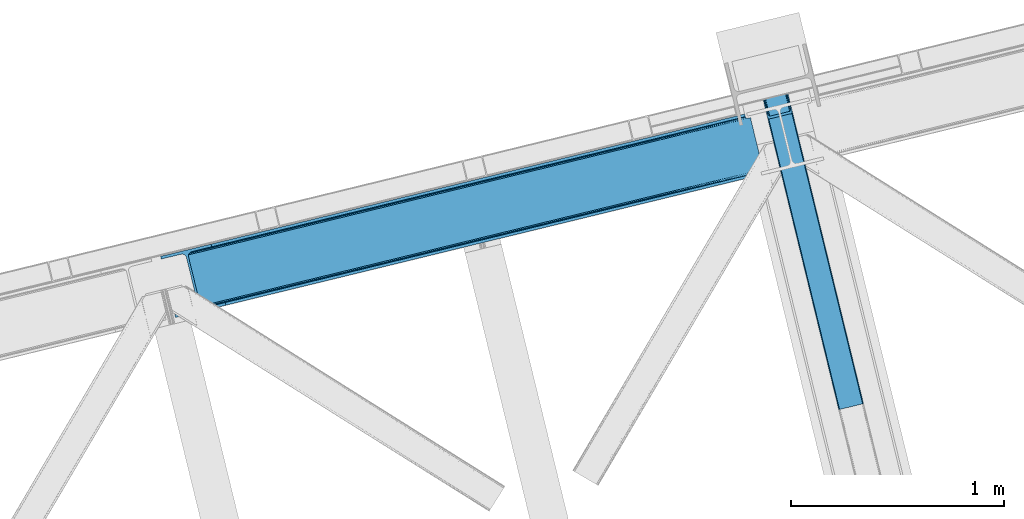
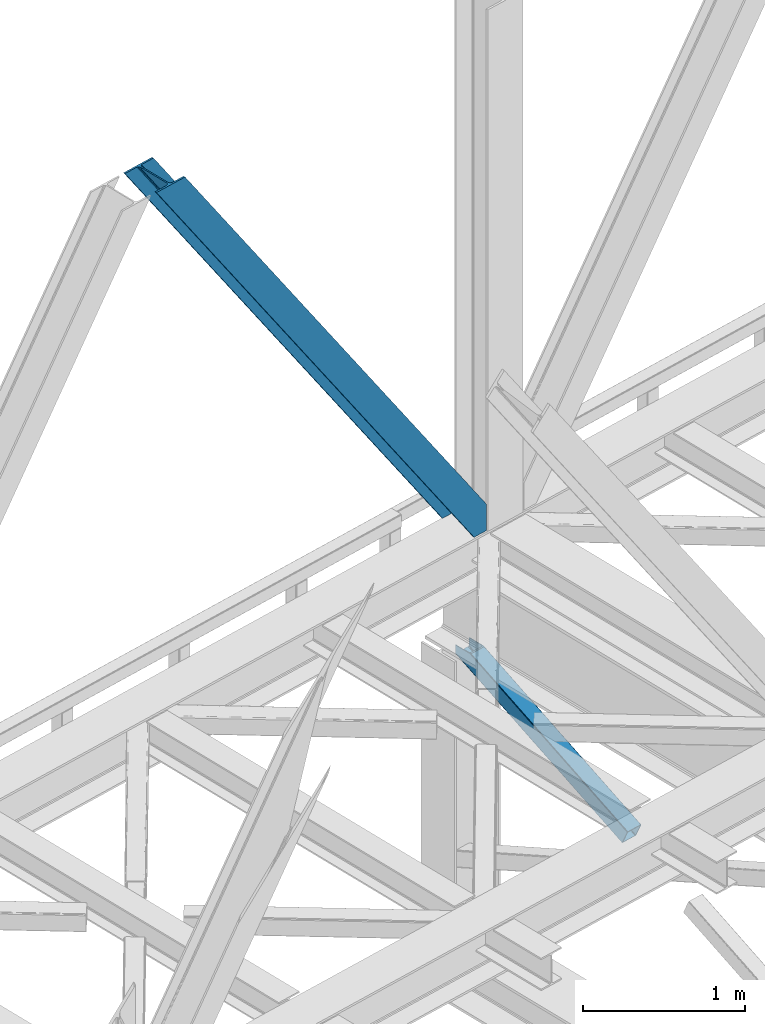
# One storey, part 30 of 93: 2 members.
"""IFC4 building model written with IfcOpenShell, lengths in millimetres."""

from ifc_helpers import new_model, entity, si_unit, converted_unit, derived_unit, direction, frame, origin, place, context, subcontext, project, spatial, triangles, type_object, element, save


model = new_model("IFC4")

# Units and contexts
model_context = context("Model", 3, precision=0.01, world=origin(), true_north=direction((6.12303176911189e-17, 1.0)))
plan_context = context("Plan", 3, precision=0.01, world=origin(), true_north=direction((6.12303176911189e-17, 1.0)))
body_context = subcontext(model_context, "Body", "Model", "MODEL_VIEW")
ifc_project = project(units=[si_unit("LENGTHUNIT", "METRE", prefix="MILLI"), si_unit("AREAUNIT", "SQUARE_METRE"), si_unit("VOLUMEUNIT", "CUBIC_METRE"), converted_unit("PLANEANGLEUNIT", "DEGREE", entity("IfcRatioMeasure", 0.0174532925199433), si_unit("PLANEANGLEUNIT", "RADIAN"), dimensions=[0, 0, 0, 0, 0, 0, 0]), si_unit("MASSUNIT", "GRAM", prefix="KILO"), derived_unit("MASSDENSITYUNIT", [(si_unit("MASSUNIT", "GRAM", prefix="KILO"), 1), (si_unit("LENGTHUNIT", "METRE"), -3)]), derived_unit("MOMENTOFINERTIAUNIT", [(si_unit("LENGTHUNIT", "METRE"), 4)]), si_unit("TIMEUNIT", "SECOND"), si_unit("FREQUENCYUNIT", "HERTZ"), si_unit("THERMODYNAMICTEMPERATUREUNIT", "DEGREE_CELSIUS"), derived_unit("THERMALTRANSMITTANCEUNIT", [(si_unit("MASSUNIT", "GRAM", prefix="KILO"), 1), (si_unit("THERMODYNAMICTEMPERATUREUNIT", "KELVIN"), -1), (si_unit("TIMEUNIT", "SECOND"), -3)]), derived_unit("VOLUMETRICFLOWRATEUNIT", [(si_unit("LENGTHUNIT", "METRE"), 3), (si_unit("TIMEUNIT", "SECOND"), -1)]), derived_unit("MASSFLOWRATEUNIT", [(si_unit("MASSUNIT", "GRAM", prefix="KILO"), 1), (si_unit("TIMEUNIT", "SECOND"), -1)]), derived_unit("ROTATIONALFREQUENCYUNIT", [(si_unit("TIMEUNIT", "SECOND"), -1)]), si_unit("ELECTRICCURRENTUNIT", "AMPERE"), si_unit("ELECTRICVOLTAGEUNIT", "VOLT"), si_unit("POWERUNIT", "WATT"), si_unit("FORCEUNIT", "NEWTON", prefix="KILO"), si_unit("ILLUMINANCEUNIT", "LUX"), si_unit("LUMINOUSFLUXUNIT", "LUMEN"), si_unit("LUMINOUSINTENSITYUNIT", "CANDELA"), derived_unit("USERDEFINED", [(si_unit("MASSUNIT", "GRAM", prefix="KILO"), -1), (si_unit("LENGTHUNIT", "METRE"), -2), (si_unit("TIMEUNIT", "SECOND"), 3), (si_unit("LUMINOUSFLUXUNIT", "LUMEN"), 1)]), derived_unit("LINEARVELOCITYUNIT", [(si_unit("LENGTHUNIT", "METRE"), 1), (si_unit("TIMEUNIT", "SECOND"), -1)]), si_unit("PRESSUREUNIT", "PASCAL"), derived_unit("USERDEFINED", [(si_unit("LENGTHUNIT", "METRE"), -2), (si_unit("MASSUNIT", "GRAM", prefix="KILO"), 1), (si_unit("TIMEUNIT", "SECOND"), -2)]), derived_unit("LINEARFORCEUNIT", [(si_unit("MASSUNIT", "GRAM", prefix="KILO"), 1), (si_unit("LENGTHUNIT", "METRE"), 1), (si_unit("TIMEUNIT", "SECOND"), -2), (si_unit("LENGTHUNIT", "METRE"), -1)]), derived_unit("PLANARFORCEUNIT", [(si_unit("MASSUNIT", "GRAM", prefix="KILO"), 1), (si_unit("LENGTHUNIT", "METRE"), 1), (si_unit("TIMEUNIT", "SECOND"), -2), (si_unit("LENGTHUNIT", "METRE"), -2)])], contexts=[model_context, plan_context])

# Site, building, storey
site_placement = place(None, origin())
site = spatial("IfcSite", under=ifc_project, at=site_placement, CompositionType="ELEMENT")
building_placement = place(site_placement, origin())
building = spatial("IfcBuilding", under=site, at=building_placement, CompositionType="ELEMENT")
storey_placement = place(building_placement, frame((0.0, 0.0, 15900.0)))
storey = spatial("IfcBuildingStorey", under=building, at=storey_placement, CompositionType="ELEMENT", Elevation=15900.0)

# Members
member_type_1 = type_object("IfcMemberType", PredefinedType="BRACE")
member_1_placement = place(storey_placement, frame((-58108.1461669922, 6493.08332061768, 3694.99929199219)))
element("IfcMember", 1, at=member_1_placement, inside=storey, type_object=member_type_1, ObjectType="Steel Vertical Brace", PredefinedType="BRACE", context=body_context, shape_type="Tessellation", body=[
    triangles([(2824.16715087891, 696.208666992187, 0.781347656247817), (2824.83687744141, 695.227331542969, 1.0697021484375), (2823.33929443359, 694.862237548828, 0.0), (2821.44638671875, 702.634437561035, 0.0), (2812.37717285156, 692.190307617188, 19.5569458007813), (2812.37717285156, 692.190307617188, 0.0), (2386.756640625, 583.574263000489, 658.75048828125), (2392.34234619141, 580.919192504883, 662.07819213867), (2803.98698730469, 681.261904907226, 51.2480346679658), (2804.11256103516, 683.186206054687, 44.4996093749978), (2382.25924072266, 588.488497924805, 656.525042724606), (2808.48438720703, 690.37995300293, 26.4030395507798), (2805.01483154297, 685.664543151855, 38.2720825195283), (2805.58223876954, 687.217936706543, 34.3676696777329), (630.515002441411, 150.046073913574, 3288.98063964843), (624.692102050787, 150.036772155762, 3285.05529785156), (211.331286621098, 47.865682983399, 3911.00081176758), (202.862036132814, 47.2110717773439, 3911.00081176758), (619.106396484378, 152.691261291504, 3281.72759399414), (195.034606933594, 49.3190826416021, 3911.00081176758), (614.608996582036, 157.60549621582, 3279.50447387695), (189.03962402344, 53.8676422119142, 3911.00081176758), (611.88358154297, 164.031266784668, 3278.7231262207), (185.784008789065, 60.1649322509766, 3911.00081176758), (2804.10325927735, 679.880593872071, 63.6403015136711), (2398.16524658204, 580.929075622559, 666.003533935545), (1950.42978515625, 473.1990234375, 1317.82188720703), (1956.25268554688, 473.208325195313, 1321.74955444336), (1508.5172241211, 365.478273010254, 1973.56790771484), (1514.34012451172, 365.487574768066, 1977.49324951172), (1072.42756347657, 257.766824340821, 2633.23694458008), (1066.60466308594, 257.757522583008, 2629.3116027832), (1944.84407958985, 475.853512573242, 1314.49418334961), (1502.93151855469, 368.132762145996, 1970.23787841797), (1061.01895751953, 260.41201171875, 2625.98389892578), (1940.3466796875, 480.767747497559, 1312.27106323242), (1498.43411865235, 373.046997070313, 1968.01475830078), (1056.52155761719, 265.326246643067, 2623.75845336914), (2379.5338256836, 594.91368713379, 655.74602050781), (1937.62126464844, 487.192936706543, 1311.48971557617), (1495.70870361329, 379.47276763916, 1967.23341064453), (1053.79614257813, 271.752017211914, 2622.97710571289), (2766.2637084961, 929.006085205078, 0.0), (2324.35114746094, 821.285334777832, 655.74602050781), (1882.43858642579, 713.564584350586, 1311.48971557617), (1440.52602539063, 605.844415283203, 1967.23341064453), (998.613464355469, 498.123664855957, 2622.97710571289), (556.705554199223, 390.402914428711, 3278.7231262207), (130.605981445318, 286.53657989502, 3911.00081176758), (303.26520996094, 70.2747802734375, 3911.00081176758), (2804.10325927735, 679.880593872071, 200.055230712889), (2807.13563232422, 667.239505004883, 200.120343017577), (2804.2939453125, 678.898095703125, 200.120343017577), (306.344091796876, 57.6441558837896, 3911.00081176758), (2807.13563232422, 667.239505004883, 0.0), (2804.2939453125, 678.898095703125, 0.0), (2803.9962890625, 682.092668151856, 0.0), (2804.11256103516, 683.186206054687, 2.42078247070094), (2804.71717529297, 685.456997680664, 5.12991943359157), (2805.58223876954, 687.217936706543, 5.67639770507594), (2807.01470947266, 689.087008666992, 4.89505004882813), (2808.48438720703, 690.37995300293, 3.35328369140552), (2811.03771972656, 691.772309875489, 0.0), (2705.51857910157, 642.469505310059, 0.0), (69.8608520507842, 0.0, 3911.00081176758), (2794.37362060547, 677.509226989746, 0.0), (2801.99641113282, 681.140400695801, 0.0), (2702.44434814453, 655.099548339844, 0.0), (66.7819702148481, 12.6300430297852, 3911.00081176758), (1480.00268554688, 357.117155456544, 1950.37164916992), (1034.28570556641, 248.469717407227, 2611.75686035156), (588.573376464847, 139.822279357911, 3273.1420715332), (158.71589355469, 35.0397216796873, 3911.00081176758), (1925.71501464844, 465.76459350586, 1288.98643798828), (2371.42734375, 574.412031555176, 627.598901367186), (2376.60377197266, 577.083380126954, 631.526568603513), (2380.34307861328, 582.010986328125, 634.854272460936), (2381.53370361328, 595.402029418946, 637.858740234373), (2811.39583740235, 700.184587097168, 0.0), (2811.09353027344, 693.083276367188, 0.0), (2382.07320556641, 588.443151855469, 637.077392578125), (598.679736328129, 160.81227722168, 3283.40191040039), (599.21923828125, 153.853399658204, 3282.62056274414), (175.738110351565, 57.7150817871097, 3911.00081176758), (175.747412109376, 50.6283050537113, 3911.00081176758), (597.484460449225, 147.420652770997, 3280.39744262695), (172.515051269533, 43.8298828124998, 3911.00081176758), (593.749804687504, 142.493627929688, 3277.06973876953), (166.5340209961, 38.3557983398441, 3911.00081176758), (1936.36087646485, 479.795713806153, 1298.46260375976), (1935.82137451172, 486.754591369629, 1299.24395141601), (1490.10904541016, 378.107153320313, 1960.63148803711), (1490.64389648438, 371.148275756836, 1959.85014038086), (1044.93156738282, 262.50083770752, 2621.2353515625), (1044.39206542969, 269.459715270997, 2622.01669921875), (1934.62609863281, 473.362966918946, 1296.23948364258), (1488.91376953125, 364.715528869629, 1957.62469482422), (1043.20144042969, 256.068090820313, 2619.01223144531), (1930.8914428711, 468.435942077637, 1292.91177978515), (1485.17446289063, 359.788504028321, 1954.2969909668), (1039.46213378906, 251.141065979004, 2615.68220214844), (2756.21315917969, 926.556234741211, 0.0), (2326.35567626954, 821.773677062988, 637.858740234373), (1434.9263671875, 604.478800964355, 1960.63148803711), (1880.64334716797, 713.126239013672, 1299.24395141601), (989.214038085942, 495.831362915039, 2622.01669921875), (543.501708984375, 387.183924865722, 3283.40191040039), (120.555432128909, 284.086729431153, 3911.00081176758), (2752.67849121094, 932.723881530762, 0.0), (2753.40867919922, 934.106936645509, 0.0), (2752.02736816407, 933.862184143067, 0.0), (2764.37080078125, 936.778866577149, 0.0), (2753.40867919922, 934.106936645509, 19.5569458007813), (2765.86838378906, 937.143960571289, 1.0697021484375), (2765.72420654297, 935.965544128419, 0.781347656247817), (2325.54642333985, 834.677540588379, 658.75048828125), (2749.12056884766, 933.923226928711, 26.4030395507798), (2745.08825683594, 935.395230102539, 34.3676696777329), (2323.81629638672, 828.244793701172, 656.525042724606), (2743.50695800781, 936.560275268555, 38.5441589355469), (556.166052246095, 397.361791992188, 3279.50447387695), (130.592028808598, 293.624519348145, 3911.00081176758), (557.896179199219, 403.794538879395, 3281.72759399414), (133.824389648442, 300.422360229492, 3911.00081176758), (561.635485839848, 408.721563720704, 3285.05529785156), (139.805419921875, 305.895863342285, 3911.00081176758), (566.811914062506, 411.393493652344, 3288.98063964843), (147.628198242193, 309.212521362305, 3911.00081176758), (2740.93037109375, 939.947277832031, 51.2480346679658), (2740.39552001953, 941.22801361084, 63.6403015136711), (2329.28572998047, 839.604565429688, 662.07819213867), (2334.45750732422, 842.276495361329, 666.003533935545), (2742.08843994141, 938.421208190918, 45.5251281738274), (1881.90373535157, 720.524043273926, 1312.27106323242), (1439.99117431641, 612.80329284668, 1968.01475830078), (998.07861328125, 505.082542419434, 2623.75845336914), (1883.63386230469, 726.956790161133, 1314.49418334961), (1441.72130126954, 619.236039733887, 1970.23787841797), (999.808740234381, 511.515289306641, 2625.98389892578), (1887.37316894531, 731.883815002441, 1317.82188720703), (1445.46060791016, 624.163064575196, 1973.56790771484), (1003.548046875, 516.442314147949, 2629.3116027832), (1892.54494628907, 734.555744934082, 1321.74955444336), (1450.63238525391, 626.834994506836, 1977.49324951172), (1008.72447509766, 519.11424407959, 2633.23694458008), (2740.39552001953, 941.22801361084, 200.055230712889), (239.557470703126, 331.622200012207, 3911.00081176758), (2749.12056884766, 933.923226928711, 3.35328369140552), (2745.08825683594, 935.395230102539, 5.67639770507594), (2747.22301025391, 934.392384338379, 4.89272460937354), (2743.50695800781, 936.560275268555, 5.12991943359157), (2740.11646728516, 942.189001464844, 0.0), (2741.92565917969, 938.297378540039, 2.42078247070094), (2740.11646728516, 942.189001464844, 200.120343017577), (2741.32104492188, 939.215927124023, 0.0), (2323.63026123047, 828.2000289917, 637.077392578125), (2319.13286132813, 833.113682556153, 634.854272460936), (2313.54715576172, 835.768171691895, 631.526568603513), (2307.7242553711, 835.758869934082, 627.598901367186), (2730.66588134766, 938.856646728516, 0.0), (2739.1072265625, 939.140931701661, 0.0), (524.865637207033, 401.16969909668, 3273.1420715332), (530.693188476565, 401.178419494629, 3277.06973876953), (103.477404785161, 297.041171264648, 3911.00081176758), (95.0081542968765, 296.387141418457, 3911.00081176758), (536.278894042975, 398.523930358887, 3280.39744262695), (111.309484863283, 294.933160400391, 3911.00081176758), (540.776293945317, 393.610276794434, 3282.62056274414), (117.304467773443, 290.384600830078, 3911.00081176758), (1867.83017578125, 727.120733642579, 1292.91177978515), (1862.00727539063, 727.112013244629, 1288.98643798828), (1416.29494628907, 618.463993835449, 1950.37164916992), (1422.11784667969, 618.473295593262, 1954.2969909668), (976.405517578125, 509.825857543946, 2615.68220214844), (970.582617187501, 509.817137145997, 2611.75686035156), (1873.41588134766, 724.466244506836, 1296.23948364258), (1427.70355224609, 615.81880645752, 1957.62469482422), (981.991223144534, 507.171368408203, 2619.01223144531), (1877.91793212891, 719.552590942383, 1298.46260375976), (1432.20095214844, 610.905152893067, 1959.85014038086), (986.488623046876, 502.25771484375, 2621.2353515625), (2737.27478027344, 953.847592163086, 200.120343017577), (236.47858886719, 344.252243041992, 3911.00081176758), (2737.27478027344, 953.847592163086, 0.0), (0.0, 286.608087158203, 3911.00081176758), (3.07888183594332, 273.977462768555, 3911.00081176758), (2635.65772705078, 929.077592468262, 0.0), (2638.73660888672, 916.446968078613, 0.0)], [[1, 2, 3], [3, 4, 1], [2, 5, 6], [6, 3, 2], [7, 8, 9], [9, 10, 7], [11, 12, 5], [5, 1, 11], [5, 2, 1], [11, 7, 13], [13, 14, 11], [14, 12, 11], [15, 16, 17], [18, 17, 16], [16, 19, 18], [20, 18, 19], [19, 21, 20], [22, 20, 21], [21, 23, 22], [24, 22, 23], [10, 13, 7], [25, 9, 8], [8, 26, 25], [26, 8, 27], [27, 28, 26], [28, 27, 29], [29, 30, 28], [30, 29, 31], [32, 31, 29], [31, 32, 16], [16, 15, 31], [8, 7, 27], [33, 27, 7], [27, 33, 34], [34, 29, 27], [29, 34, 35], [35, 32, 29], [32, 35, 16], [19, 16, 35], [7, 11, 36], [36, 33, 7], [33, 36, 34], [37, 34, 36], [34, 37, 35], [38, 35, 37], [35, 38, 21], [21, 19, 35], [1, 4, 11], [39, 11, 4], [11, 39, 40], [40, 36, 11], [36, 40, 41], [41, 37, 36], [37, 41, 42], [42, 38, 37], [38, 42, 21], [23, 21, 42], [4, 43, 44], [45, 39, 44], [41, 40, 45], [41, 45, 46], [44, 39, 4], [45, 40, 39], [42, 41, 46], [46, 47, 42], [47, 48, 23], [49, 24, 48], [47, 23, 42], [48, 24, 23], [50, 51, 30], [30, 31, 50], [31, 15, 50], [17, 50, 15], [28, 30, 51], [51, 25, 26], [26, 28, 51], [52, 53, 54], [53, 51, 50], [50, 54, 53], [52, 55, 53], [56, 53, 55], [56, 9, 25], [56, 57, 58], [58, 10, 56], [10, 9, 56], [59, 60, 14], [14, 13, 59], [10, 58, 59], [60, 61, 12], [12, 14, 60], [5, 62, 63], [63, 6, 5], [5, 12, 62], [61, 62, 12], [13, 10, 59], [25, 51, 53], [53, 56, 25], [54, 64, 52], [54, 65, 64], [64, 55, 52], [56, 66, 67], [55, 66, 56], [67, 57, 56], [64, 66, 55], [64, 68, 66], [68, 64, 69], [65, 69, 64], [69, 70, 68], [71, 69, 72], [69, 71, 70], [69, 73, 72], [74, 68, 70], [66, 68, 75], [74, 75, 68], [67, 76, 58], [76, 77, 59], [59, 58, 76], [76, 67, 66], [78, 79, 80], [81, 60, 59], [81, 80, 62], [62, 61, 81], [61, 60, 81], [80, 63, 62], [59, 77, 81], [80, 81, 78], [82, 83, 84], [85, 84, 83], [83, 86, 85], [87, 85, 86], [86, 88, 87], [89, 87, 88], [88, 72, 89], [73, 89, 72], [66, 75, 76], [58, 57, 67], [78, 81, 90], [90, 91, 78], [91, 90, 92], [93, 92, 90], [92, 93, 94], [94, 95, 92], [95, 94, 83], [83, 82, 95], [81, 77, 90], [96, 90, 77], [90, 96, 93], [97, 93, 96], [93, 97, 94], [98, 94, 97], [94, 98, 83], [86, 83, 98], [77, 76, 99], [99, 96, 77], [96, 99, 100], [100, 97, 96], [97, 100, 101], [101, 98, 97], [98, 101, 88], [88, 86, 98], [76, 75, 99], [74, 99, 75], [99, 74, 70], [70, 100, 99], [100, 70, 101], [71, 101, 70], [101, 71, 72], [72, 88, 101], [102, 79, 78], [91, 103, 78], [104, 105, 91], [104, 91, 92], [78, 103, 102], [91, 105, 103], [106, 104, 92], [92, 95, 106], [95, 82, 107], [84, 108, 82], [95, 107, 106], [82, 108, 107], [109, 102, 110], [6, 79, 80], [6, 80, 63], [110, 111, 109], [3, 79, 6], [79, 4, 102], [3, 4, 79], [43, 102, 4], [102, 112, 110], [112, 102, 43], [113, 114, 110], [112, 110, 114], [114, 115, 112], [43, 112, 115], [116, 117, 118], [119, 115, 113], [113, 116, 119], [113, 117, 116], [115, 114, 113], [118, 120, 116], [48, 121, 122], [122, 49, 48], [121, 123, 124], [124, 122, 121], [123, 125, 126], [126, 124, 123], [125, 127, 128], [128, 126, 125], [129, 130, 131], [132, 131, 130], [133, 116, 120], [116, 133, 129], [131, 116, 129], [43, 115, 119], [119, 44, 43], [44, 119, 45], [134, 45, 119], [45, 134, 46], [135, 46, 134], [46, 135, 136], [136, 47, 46], [47, 136, 121], [121, 48, 47], [119, 116, 134], [137, 134, 116], [134, 137, 138], [138, 135, 134], [135, 138, 139], [139, 136, 135], [136, 139, 121], [123, 121, 139], [116, 131, 140], [140, 137, 116], [137, 140, 138], [141, 138, 140], [138, 141, 139], [142, 139, 141], [139, 142, 125], [125, 123, 139], [131, 132, 140], [143, 140, 132], [140, 143, 141], [144, 141, 143], [141, 144, 145], [145, 142, 141], [142, 145, 127], [127, 125, 142], [144, 146, 147], [147, 127, 145], [127, 147, 128], [145, 144, 147], [146, 144, 143], [143, 132, 146], [130, 146, 132], [113, 110, 111], [148, 117, 113], [149, 118, 117], [117, 148, 150], [151, 133, 120], [118, 149, 151], [151, 120, 118], [152, 133, 153], [152, 129, 133], [146, 130, 154], [152, 154, 130], [130, 129, 152], [153, 155, 152], [151, 153, 133], [117, 150, 149], [111, 148, 113], [156, 150, 148], [156, 149, 150], [148, 109, 156], [148, 111, 109], [156, 157, 151], [151, 149, 156], [103, 156, 109], [158, 159, 160], [158, 153, 151], [158, 161, 153], [161, 155, 153], [151, 157, 158], [160, 161, 158], [162, 163, 164], [164, 165, 162], [163, 166, 167], [167, 164, 163], [166, 168, 169], [169, 167, 166], [168, 107, 108], [108, 169, 168], [109, 102, 103], [159, 158, 170], [170, 171, 159], [171, 170, 172], [173, 172, 170], [172, 173, 174], [174, 175, 172], [175, 174, 163], [163, 162, 175], [158, 157, 176], [176, 170, 158], [170, 176, 173], [177, 173, 176], [173, 177, 174], [178, 174, 177], [174, 178, 163], [166, 163, 178], [157, 156, 176], [179, 176, 156], [176, 179, 180], [180, 177, 176], [177, 180, 181], [181, 178, 177], [178, 181, 168], [168, 166, 178], [156, 103, 105], [105, 179, 156], [179, 105, 104], [104, 180, 179], [180, 104, 181], [106, 181, 104], [181, 106, 168], [107, 168, 106], [146, 154, 147], [154, 182, 183], [183, 147, 154], [154, 152, 184], [184, 182, 154], [108, 84, 49], [87, 89, 18], [73, 65, 54], [69, 65, 73], [89, 73, 17], [84, 85, 22], [85, 87, 20], [167, 126, 164], [185, 165, 183], [165, 164, 128], [185, 186, 165], [167, 169, 124], [169, 108, 122], [49, 84, 24], [17, 18, 89], [22, 85, 20], [18, 20, 87], [22, 24, 84], [54, 17, 73], [54, 50, 17], [128, 164, 126], [124, 169, 122], [49, 122, 108], [124, 126, 167], [128, 183, 165], [183, 128, 147], [152, 160, 184], [155, 161, 152], [152, 161, 160], [160, 187, 184], [187, 160, 188], [183, 187, 185], [187, 183, 182], [184, 187, 182], [172, 186, 188], [162, 186, 175], [162, 165, 186], [172, 175, 186], [188, 171, 172], [159, 171, 188], [188, 160, 159], [187, 188, 185], [186, 185, 188]]),
])
member_type_2 = type_object("IfcMemberType", PredefinedType="BRACE")
member_2_placement = place(storey_placement, frame((-55294.262109375, 6062.41018981934, 1850.35374755859)))
element("IfcMember", 2, at=member_2_placement, inside=storey, type_object=member_type_2, ObjectType="Steel Vertical Brace", PredefinedType="BRACE", context=body_context, shape_type="Tessellation", body=[
    triangles([(109.783996582031, 1519.24680175781, 671.707836914062), (462.204345703125, 73.4902816772465, 0.0), (359.21993408203, 48.3865814208984, 0.0), (6.79958496093604, 1494.14310150147, 671.707836914062), (464.859997558589, 73.9117675781254, 0.48601684570167), (467.213342285155, 73.843167114258, 1.86965332031104), (112.188500976561, 1519.8328125, 672.832186889649), (468.906262207027, 73.2943634033209, 3.93929443359229), (114.593005371091, 1520.41882324219, 673.956536865233), (469.687609863278, 72.3502349853516, 6.38100585937354), (115.588293457025, 1520.66183166504, 676.672650146484), (116.588232421869, 1520.90425872803, 679.387600708007), (353.099377441402, 43.9310394287113, 6.38100585937354), (0.0, 1492.48564453125, 679.387600708007), (0.99528808593459, 1492.72807159424, 676.672650146484), (353.355175781246, 45.1274780273443, 3.93929443359229), (1.99057617186918, 1492.97108001709, 673.956536865233), (354.610913085933, 46.3948425292974, 1.86965332031104), (4.39508056640625, 1493.55709075928, 672.832186889649), (356.671252441403, 47.5395401000978, 0.48601684570167), (144.939990234372, 1404.59100952148, 741.646591186523), (116.588232421869, 1520.90425872803, 741.646591186523), (480.012561035153, 29.9801467895513, 102.993713378906), (28.3517578124956, 1376.17181396484, 741.646591186523), (0.0, 1492.48564453125, 741.646591186523), (363.428979492186, 1.5615325927738, 102.993713378906), (476.445336914061, 26.3722274780275, 108.888702392578), (144.460949707027, 1388.29549255371, 741.646591186523), (142.168066406244, 1386.40316619873, 741.646591186523), (473.896655273435, 25.5246047973633, 109.37471923828), (478.505676269531, 27.5163436889652, 107.505065917969), (145.795751953119, 1392.41675262451, 741.646591186523), (479.75676269531, 28.7837081909183, 105.435424804688), (145.963183593747, 1398.13907775879, 741.646591186523), (39.1836547851563, 1361.29946594238, 741.646591186523), (370.912243652339, 0.420904541016171, 109.37471923828), (364.205676269528, 0.61682281494177, 105.435424804688), (30.4120971679658, 1369.97219238281, 741.646591186523), (365.90324707031, 0.0686004638673694, 107.505065917969), (33.1933227539048, 1364.96900939942, 741.646591186523), (368.256591796875, 0.0, 108.888702392578), (36.2722045898408, 1361.92326507568, 741.646591186523), (138.061340332031, 1403.03994140625, 741.646591186523), (137.200927734375, 1415.21419830322, 741.646591186523), (111.728063964838, 1519.72061004639, 741.646591186523), (138.228771972652, 1408.76226654053, 741.646591186523), (136.726538085932, 1398.91926269531, 741.646591186523), (134.433654785156, 1397.02635498047, 741.646591186523), (35.1745971679629, 1377.9600769043, 741.646591186523), (32.3933715820313, 1382.96384124756, 741.646591186523), (30.333032226561, 1389.16346282959, 741.646591186523), (4.85551757812209, 1493.66929321289, 741.646591186523), (38.2534790039063, 1374.91491394043, 741.646591186523), (41.1649291992144, 1374.29111480713, 741.646591186523), (474.668701171875, 30.7952133178715, 98.4370147705085), (474.412902832031, 29.5981933593757, 100.87872619629), (473.161816406246, 28.3308288574226, 102.948367309571), (471.101477050775, 27.1867126464849, 104.330841064453), (468.552795410156, 26.3390899658207, 104.816857910155), (375.284069824214, 3.60384979248101, 104.816857910155), (372.62841796875, 3.18236389160211, 104.330841064453), (370.275073242185, 3.25096435546948, 102.948367309571), (368.577502441403, 3.79976806640661, 100.87872619629), (367.800805664061, 4.743896484375, 98.4370147705085), (111.728063964838, 1519.72061004639, 684.873312377931), (465.315783691403, 69.1672897338867, 10.9377044677749), (4.85551757812209, 1493.66929321289, 684.873312377931), (358.443237304688, 43.1165542602539, 10.9377044677749), (462.84151611328, 70.6602218627932, 6.42635192871239), (464.539086914061, 70.1119995117188, 8.49599304199364), (460.488171386714, 70.7294036865242, 5.04387817382667), (457.83251953125, 70.3079177856453, 4.557861328125), (359.954772949219, 45.58035736084, 6.42635192871239), (362.015112304682, 46.7250549316414, 5.04387817382667), (358.703686523433, 44.3135742187505, 8.49599304199364), (364.563793945308, 47.572096252442, 4.557861328125), (11.6597534179673, 1495.32733154297, 677.193548583986), (9.2552490234375, 1494.74132080078, 678.31789855957), (6.85074462890043, 1494.15531005859, 679.443411254884), (104.928479003902, 1518.06257171631, 677.193548583986), (107.332983398432, 1518.6485824585, 678.31789855957), (109.737487792969, 1519.23459320068, 679.443411254884), (5.85545654296584, 1493.91230163574, 682.158361816408), (110.732775878903, 1519.47760162354, 682.158361816408)], [[1, 2, 3], [3, 4, 1], [5, 2, 1], [6, 5, 7], [8, 6, 9], [10, 8, 11], [11, 12, 10], [9, 11, 8], [7, 9, 6], [1, 7, 5], [13, 14, 15], [16, 15, 17], [18, 17, 19], [20, 19, 4], [4, 3, 20], [19, 20, 18], [17, 18, 16], [15, 16, 13], [12, 21, 10], [21, 12, 22], [23, 10, 21], [24, 14, 13], [24, 25, 14], [13, 26, 24], [27, 28, 29], [29, 30, 27], [31, 32, 28], [28, 27, 31], [33, 34, 32], [32, 31, 33], [23, 21, 34], [34, 33, 23], [30, 29, 35], [35, 36, 30], [37, 38, 26], [24, 26, 38], [39, 40, 37], [38, 37, 40], [41, 42, 39], [40, 39, 42], [36, 35, 41], [42, 41, 35], [43, 34, 21], [22, 44, 21], [44, 22, 45], [44, 46, 21], [46, 43, 21], [47, 34, 43], [32, 29, 28], [32, 34, 47], [32, 48, 29], [29, 48, 35], [47, 48, 32], [24, 38, 49], [49, 50, 24], [50, 51, 24], [51, 25, 24], [52, 25, 51], [38, 53, 49], [54, 40, 35], [54, 35, 48], [54, 53, 40], [35, 40, 42], [53, 38, 40], [44, 55, 46], [56, 46, 55], [46, 56, 43], [57, 43, 56], [43, 57, 47], [58, 47, 57], [47, 58, 48], [59, 48, 58], [48, 59, 54], [60, 54, 59], [54, 60, 61], [61, 53, 54], [53, 61, 62], [62, 49, 53], [49, 62, 63], [63, 50, 49], [50, 63, 64], [64, 51, 50], [44, 65, 66], [44, 45, 65], [66, 55, 44], [67, 51, 68], [51, 67, 52], [64, 68, 51], [55, 23, 56], [57, 33, 31], [31, 27, 57], [23, 55, 10], [23, 33, 57], [57, 56, 23], [59, 30, 36], [30, 58, 57], [59, 58, 30], [30, 57, 27], [6, 69, 5], [66, 10, 55], [69, 8, 10], [70, 10, 66], [8, 69, 6], [69, 2, 5], [10, 70, 69], [69, 71, 2], [2, 72, 3], [72, 2, 71], [62, 26, 63], [36, 60, 59], [61, 36, 62], [36, 61, 60], [62, 36, 41], [64, 63, 26], [41, 39, 62], [37, 62, 39], [64, 26, 13], [37, 26, 62], [73, 20, 3], [74, 73, 3], [75, 13, 73], [76, 3, 72], [3, 76, 74], [18, 20, 73], [13, 68, 64], [16, 73, 13], [68, 13, 75], [73, 16, 18], [77, 1, 4], [4, 19, 78], [19, 17, 15], [19, 79, 78], [4, 78, 77], [79, 19, 15], [80, 1, 77], [9, 7, 11], [7, 1, 81], [81, 82, 7], [7, 82, 11], [80, 81, 1], [11, 82, 12], [83, 14, 67], [15, 14, 79], [83, 79, 14], [25, 67, 14], [25, 52, 67], [12, 84, 65], [84, 12, 82], [65, 22, 12], [22, 65, 45], [72, 80, 76], [77, 76, 80], [66, 65, 84], [70, 84, 82], [69, 82, 81], [71, 81, 80], [80, 72, 71], [81, 71, 69], [82, 69, 70], [84, 70, 66], [74, 76, 77], [73, 74, 78], [75, 73, 79], [68, 75, 83], [83, 67, 68], [79, 83, 75], [78, 79, 73], [77, 78, 74]]),
])

save(model, "model.ifc")
